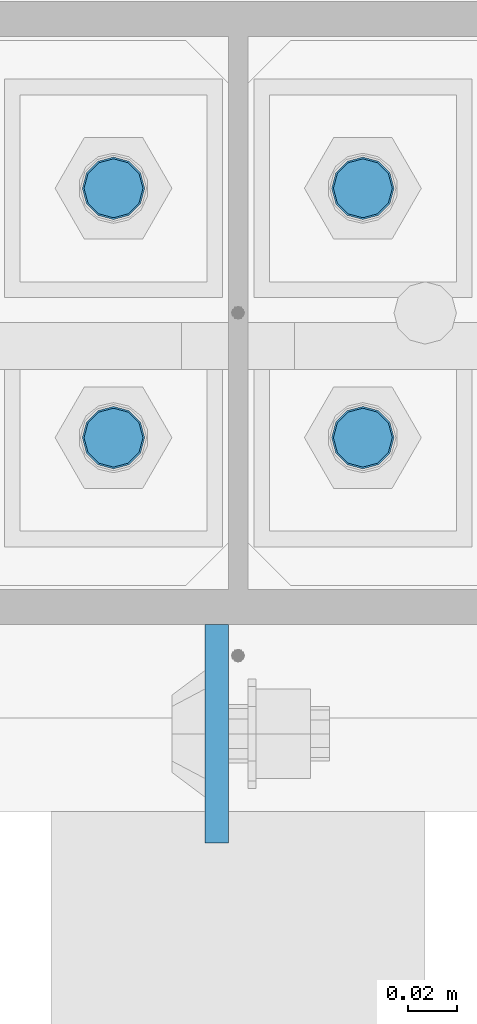
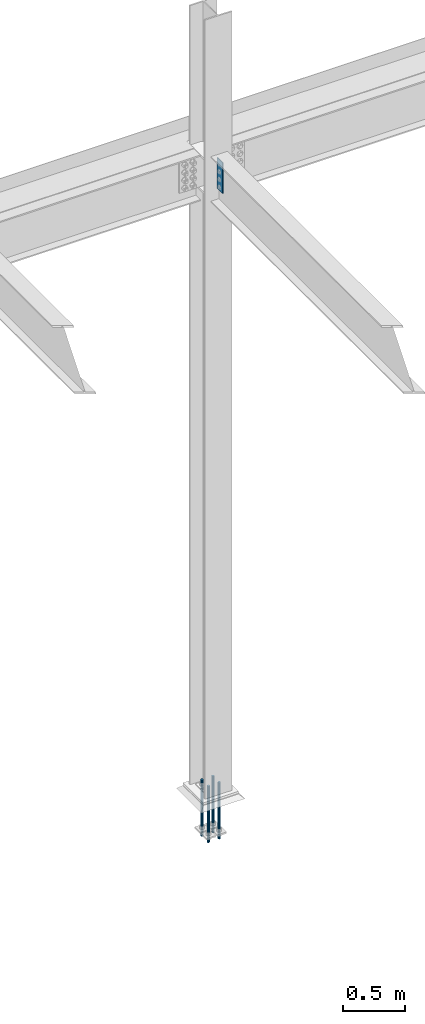
# One storey, part 1603 of 3843: 5 columns, 2 elements without a shape of their own.
"""IFC2X3 building model written with IfcOpenShell, lengths in millimetres."""

from ifc_helpers import new_model, si_unit, frame, origin_with_axes, place, context, subcontext, project, spatial, faceted_brep, material, type_object, element, aggregate, save


model = new_model("IFC2X3")

# Units and contexts
model_context = context("Model", 3, precision=1e-05, world=origin_with_axes())
body_context = subcontext(model_context, "Body", "Model", "MODEL_VIEW")
ifc_project = project(units=[si_unit("LENGTHUNIT", "METRE", prefix="MILLI"), si_unit("AREAUNIT", "SQUARE_METRE"), si_unit("VOLUMEUNIT", "CUBIC_METRE"), si_unit("MASSUNIT", "GRAM", prefix="KILO"), si_unit("TIMEUNIT", "SECOND"), si_unit("PLANEANGLEUNIT", "RADIAN"), si_unit("SOLIDANGLEUNIT", "STERADIAN"), si_unit("THERMODYNAMICTEMPERATUREUNIT", "DEGREE_CELSIUS"), si_unit("LUMINOUSINTENSITYUNIT", "LUMEN")], contexts=[model_context])

# Site, building, storey
site_placement = place(None, origin_with_axes())
site = spatial("IfcSite", under=ifc_project, at=site_placement, CompositionType="ELEMENT")
building_placement = place(site_placement, origin_with_axes())
building = spatial("IfcBuilding", under=site, at=building_placement, Name="Undefined", CompositionType="ELEMENT")
storey_placement = place(building_placement, origin_with_axes())
storey = spatial("IfcBuildingStorey", under=building, at=storey_placement, Name="Undefined", CompositionType="ELEMENT", Elevation=0.0)

# Assembly, columns
assembly_1_placement = place(storey_placement, origin_with_axes())
assembly_1 = element("IfcElementAssembly", 1, at=assembly_1_placement, inside=storey, Name="TEMPLATE", AssemblyPlace="NOTDEFINED", PredefinedType="RIGID_FRAME")
ifc_material_1 = material(Name="Undefined/F1554-GR.55")
column_type_1 = type_object("IfcColumnType", PredefinedType="NOTDEFINED")
column_1_placement = place(assembly_1_placement, frame((48945.8, 104508.3, 30022.8), z_axis=(0.0, -1.0, 0.0), x_axis=(0.0, 0.0, -1.0)))
column_1 = element("IfcColumn", 2, at=column_1_placement, type_object=column_type_1, material=ifc_material_1, Name="ANCHOR_ROD", context=body_context, shape_type="Brep", body=[
    faceted_brep([(-127.0, -10.3923048454162, 6.0), (-127.0, -6.0, 10.3923048454126), (-127.0, 0.0, 12.0), (-127.0, 6.0, 10.3923048454126), (-127.0, 10.3923048454162, 6.0), (-127.0, 12.0, 0.0), (-127.0, 10.3923048454162, -6.0), (-127.0, 6.0, -10.3923048454126), (-127.0, 0.0, -12.0), (-127.0, -6.0, -10.3923048454126), (-127.0, -10.3923048454162, -6.0), (-127.0, -12.0, 0.0), (0.0, 12.0, 0.0), (0.0, 10.3923048454162, -6.0), (0.0, 6.0, -10.3923048454126), (0.0, 0.0, -12.0), (0.0, -6.0, -10.3923048454126), (0.0, -10.3923048454162, -6.0), (0.0, -12.0, 0.0), (0.0, -10.3923048454162, 6.0), (0.0, -6.0, 10.3923048454126), (0.0, 0.0, 12.0), (0.0, 6.0, 10.3923048454126), (0.0, 10.3923048454162, 6.0), (0.0, -10.9985226280696, 6.34999999999854), (0.0, -6.35000000000582, 10.9985226280623), (0.0, 0.0, 12.6999999999971), (0.0, 6.35000000000582, 10.9985226280623), (0.0, 10.9985226280696, 6.34999999999854), (0.0, 12.6999999999971, 0.0), (0.0, 10.9985226280696, -6.34999999999854), (0.0, 6.35000000000582, -10.9985226280623), (0.0, 0.0, -12.6999999999971), (0.0, -6.35000000000582, -10.9985226280623), (0.0, -10.9985226280696, -6.34999999999854), (0.0, -12.6999999999971, 0.0), (304.799999999999, -12.6999999999971, 0.0), (304.799999999999, -10.9985226280623, 6.35000000000036), (304.799999999999, -6.34999999999854, 10.9985226280623), (304.799999999999, 0.0, 12.7000000000007), (304.799999999999, 6.34999999999854, 10.9985226280623), (304.799999999999, 10.9985226280623, 6.35000000000036), (304.799999999999, 12.6999999999971, 0.0), (304.799999999999, 10.9985226280623, -6.35000000000036), (304.799999999999, 6.34999999999854, -10.9985226280623), (304.799999999999, 0.0, -12.7000000000007), (304.799999999999, -6.34999999999854, -10.9985226280623), (304.799999999999, -10.9985226280623, -6.35000000000036), (304.799999999999, -6.0, 10.3923048454126), (304.799999999999, 0.0, 12.0), (304.799999999999, 6.0, 10.3923048454126), (304.799999999999, 10.3923048454162, 6.0), (304.799999999999, 12.0, 0.0), (304.799999999999, 10.3923048454162, -6.0), (304.799999999999, 6.0, -10.3923048454126), (304.799999999999, 0.0, -12.0), (304.799999999999, -6.0, -10.3923048454126), (304.799999999999, -10.3923048454162, -6.0), (304.799999999999, -12.0, 0.0), (304.799999999999, -10.3923048454162, 6.0), (431.799999999999, -6.0, -10.3923048454126), (431.799999999999, 0.0, -12.0), (431.799999999999, 6.0, -10.3923048454126), (431.799999999999, 10.3923048454162, -6.0), (431.799999999999, 12.0, 0.0), (431.799999999999, 10.3923048454162, 6.0), (431.799999999999, 6.0, 10.3923048454126), (431.799999999999, 0.0, 12.0), (431.799999999999, -6.0, 10.3923048454126), (431.799999999999, -10.3923048454162, 6.0), (431.799999999999, -12.0, 0.0), (431.799999999999, -10.3923048454162, -6.0)], [[[0, 1, 2, 3, 4, 5, 6, 7, 8, 9, 10, 11]], [[6, 5, 12, 13]], [[7, 6, 13, 14]], [[8, 7, 14, 15]], [[9, 8, 15, 16]], [[10, 9, 16, 17]], [[11, 10, 17, 18]], [[0, 11, 18, 19]], [[1, 0, 19, 20]], [[2, 1, 20, 21]], [[3, 2, 21, 22]], [[4, 3, 22, 23]], [[5, 4, 23, 12]], [[24, 25, 26, 27, 28, 29, 30, 31, 32, 33, 34, 35], [22, 21, 20, 19, 18, 17, 16, 15, 14, 13, 12, 23]], [[24, 35, 36, 37]], [[25, 24, 37, 38]], [[26, 25, 38, 39]], [[27, 26, 39, 40]], [[28, 27, 40, 41]], [[29, 28, 41, 42]], [[30, 29, 42, 43]], [[31, 30, 43, 44]], [[32, 31, 44, 45]], [[33, 32, 45, 46]], [[34, 33, 46, 47]], [[35, 34, 47, 36]], [[46, 45, 44, 43, 42, 41, 40, 39, 38, 37, 36, 47], [48, 49, 50, 51, 52, 53, 54, 55, 56, 57, 58, 59]], [[60, 61, 62, 63, 64, 65, 66, 67, 68, 69, 70, 71]], [[68, 67, 49, 48]], [[69, 68, 48, 59]], [[70, 69, 59, 58]], [[71, 70, 58, 57]], [[60, 71, 57, 56]], [[61, 60, 56, 55]], [[62, 61, 55, 54]], [[63, 62, 54, 53]], [[64, 63, 53, 52]], [[65, 64, 52, 51]], [[66, 65, 51, 50]], [[67, 66, 50, 49]]]),
])
column_2_placement = place(assembly_1_placement, frame((49047.4, 104508.3, 30022.8), z_axis=(0.0, 1.0, 0.0), x_axis=(0.0, 0.0, -1.0)))
column_2 = element("IfcColumn", 3, at=column_2_placement, type_object=column_type_1, material=ifc_material_1, Name="ANCHOR_ROD", context=body_context, shape_type="Brep", body=[
    faceted_brep([(-127.0, -10.3923048454162, 6.0), (-127.0, -6.0, 10.3923048454126), (-127.0, 0.0, 12.0), (-127.0, 6.0, 10.3923048454126), (-127.0, 10.3923048454162, 6.0), (-127.0, 12.0, 0.0), (-127.0, 10.3923048454162, -6.0), (-127.0, 6.0, -10.3923048454126), (-127.0, 0.0, -12.0), (-127.0, -6.0, -10.3923048454126), (-127.0, -10.3923048454162, -6.0), (-127.0, -12.0, 0.0), (0.0, 12.0, 0.0), (0.0, 10.3923048454162, -6.0), (0.0, 6.0, -10.3923048454126), (0.0, 0.0, -12.0), (0.0, -6.0, -10.3923048454126), (0.0, -10.3923048454162, -6.0), (0.0, -12.0, 0.0), (0.0, -10.3923048454162, 6.0), (0.0, -6.0, 10.3923048454126), (0.0, 0.0, 12.0), (0.0, 6.0, 10.3923048454126), (0.0, 10.3923048454162, 6.0), (0.0, -10.9985226280696, 6.34999999999854), (0.0, -6.35000000000582, 10.9985226280623), (0.0, 0.0, 12.6999999999971), (0.0, 6.35000000000582, 10.9985226280623), (0.0, 10.9985226280696, 6.34999999999854), (0.0, 12.6999999999971, 0.0), (0.0, 10.9985226280696, -6.34999999999854), (0.0, 6.35000000000582, -10.9985226280623), (0.0, 0.0, -12.6999999999971), (0.0, -6.35000000000582, -10.9985226280623), (0.0, -10.9985226280696, -6.34999999999854), (0.0, -12.6999999999971, 0.0), (304.799999999999, -12.6999999999971, 0.0), (304.799999999999, -10.9985226280623, 6.35000000000036), (304.799999999999, -6.34999999999854, 10.9985226280623), (304.799999999999, 0.0, 12.7000000000007), (304.799999999999, 6.34999999999854, 10.9985226280623), (304.799999999999, 10.9985226280623, 6.35000000000036), (304.799999999999, 12.6999999999971, 0.0), (304.799999999999, 10.9985226280623, -6.35000000000036), (304.799999999999, 6.34999999999854, -10.9985226280623), (304.799999999999, 0.0, -12.7000000000007), (304.799999999999, -6.34999999999854, -10.9985226280623), (304.799999999999, -10.9985226280623, -6.35000000000036), (304.799999999999, -6.0, 10.3923048454126), (304.799999999999, 0.0, 12.0), (304.799999999999, 6.0, 10.3923048454126), (304.799999999999, 10.3923048454162, 6.0), (304.799999999999, 12.0, 0.0), (304.799999999999, 10.3923048454162, -6.0), (304.799999999999, 6.0, -10.3923048454126), (304.799999999999, 0.0, -12.0), (304.799999999999, -6.0, -10.3923048454126), (304.799999999999, -10.3923048454162, -6.0), (304.799999999999, -12.0, 0.0), (304.799999999999, -10.3923048454162, 6.0), (431.799999999999, -6.0, -10.3923048454126), (431.799999999999, 0.0, -12.0), (431.799999999999, 6.0, -10.3923048454126), (431.799999999999, 10.3923048454162, -6.0), (431.799999999999, 12.0, 0.0), (431.799999999999, 10.3923048454162, 6.0), (431.799999999999, 6.0, 10.3923048454126), (431.799999999999, 0.0, 12.0), (431.799999999999, -6.0, 10.3923048454126), (431.799999999999, -10.3923048454162, 6.0), (431.799999999999, -12.0, 0.0), (431.799999999999, -10.3923048454162, -6.0)], [[[0, 1, 2, 3, 4, 5, 6, 7, 8, 9, 10, 11]], [[6, 5, 12, 13]], [[7, 6, 13, 14]], [[8, 7, 14, 15]], [[9, 8, 15, 16]], [[10, 9, 16, 17]], [[11, 10, 17, 18]], [[0, 11, 18, 19]], [[1, 0, 19, 20]], [[2, 1, 20, 21]], [[3, 2, 21, 22]], [[4, 3, 22, 23]], [[5, 4, 23, 12]], [[24, 25, 26, 27, 28, 29, 30, 31, 32, 33, 34, 35], [22, 21, 20, 19, 18, 17, 16, 15, 14, 13, 12, 23]], [[24, 35, 36, 37]], [[25, 24, 37, 38]], [[26, 25, 38, 39]], [[27, 26, 39, 40]], [[28, 27, 40, 41]], [[29, 28, 41, 42]], [[30, 29, 42, 43]], [[31, 30, 43, 44]], [[32, 31, 44, 45]], [[33, 32, 45, 46]], [[34, 33, 46, 47]], [[35, 34, 47, 36]], [[46, 45, 44, 43, 42, 41, 40, 39, 38, 37, 36, 47], [48, 49, 50, 51, 52, 53, 54, 55, 56, 57, 58, 59]], [[60, 61, 62, 63, 64, 65, 66, 67, 68, 69, 70, 71]], [[68, 67, 49, 48]], [[69, 68, 48, 59]], [[70, 69, 59, 58]], [[71, 70, 58, 57]], [[60, 71, 57, 56]], [[61, 60, 56, 55]], [[62, 61, 55, 54]], [[63, 62, 54, 53]], [[64, 63, 53, 52]], [[65, 64, 52, 51]], [[66, 65, 51, 50]], [[67, 66, 50, 49]]]),
])
column_3_placement = place(assembly_1_placement, frame((48945.8, 104609.9, 30022.8), z_axis=(0.0, -1.0, 0.0), x_axis=(0.0, 0.0, -1.0)))
column_3 = element("IfcColumn", 4, at=column_3_placement, type_object=column_type_1, material=ifc_material_1, Name="ANCHOR_ROD", context=body_context, shape_type="Brep", body=[
    faceted_brep([(-127.0, -10.3923048454162, 6.0), (-127.0, -6.0, 10.3923048454126), (-127.0, 0.0, 12.0), (-127.0, 6.0, 10.3923048454126), (-127.0, 10.3923048454162, 6.0), (-127.0, 12.0, 0.0), (-127.0, 10.3923048454162, -6.0), (-127.0, 6.0, -10.3923048454126), (-127.0, 0.0, -12.0), (-127.0, -6.0, -10.3923048454126), (-127.0, -10.3923048454162, -6.0), (-127.0, -12.0, 0.0), (0.0, 12.0, 0.0), (0.0, 10.3923048454162, -6.0), (0.0, 6.0, -10.3923048454126), (0.0, 0.0, -12.0), (0.0, -6.0, -10.3923048454126), (0.0, -10.3923048454162, -6.0), (0.0, -12.0, 0.0), (0.0, -10.3923048454162, 6.0), (0.0, -6.0, 10.3923048454126), (0.0, 0.0, 12.0), (0.0, 6.0, 10.3923048454126), (0.0, 10.3923048454162, 6.0), (0.0, -10.9985226280696, 6.34999999999854), (0.0, -6.35000000000582, 10.9985226280623), (0.0, 0.0, 12.6999999999971), (0.0, 6.35000000000582, 10.9985226280623), (0.0, 10.9985226280696, 6.34999999999854), (0.0, 12.6999999999971, 0.0), (0.0, 10.9985226280696, -6.34999999999854), (0.0, 6.35000000000582, -10.9985226280623), (0.0, 0.0, -12.6999999999971), (0.0, -6.35000000000582, -10.9985226280623), (0.0, -10.9985226280696, -6.34999999999854), (0.0, -12.6999999999971, 0.0), (304.799999999999, -12.6999999999971, 0.0), (304.799999999999, -10.9985226280623, 6.35000000000036), (304.799999999999, -6.34999999999854, 10.9985226280623), (304.799999999999, 0.0, 12.7000000000007), (304.799999999999, 6.34999999999854, 10.9985226280623), (304.799999999999, 10.9985226280623, 6.35000000000036), (304.799999999999, 12.6999999999971, 0.0), (304.799999999999, 10.9985226280623, -6.35000000000036), (304.799999999999, 6.34999999999854, -10.9985226280623), (304.799999999999, 0.0, -12.7000000000007), (304.799999999999, -6.34999999999854, -10.9985226280623), (304.799999999999, -10.9985226280623, -6.35000000000036), (304.799999999999, -6.0, 10.3923048454126), (304.799999999999, 0.0, 12.0), (304.799999999999, 6.0, 10.3923048454126), (304.799999999999, 10.3923048454162, 6.0), (304.799999999999, 12.0, 0.0), (304.799999999999, 10.3923048454162, -6.0), (304.799999999999, 6.0, -10.3923048454126), (304.799999999999, 0.0, -12.0), (304.799999999999, -6.0, -10.3923048454126), (304.799999999999, -10.3923048454162, -6.0), (304.799999999999, -12.0, 0.0), (304.799999999999, -10.3923048454162, 6.0), (431.799999999999, -6.0, -10.3923048454126), (431.799999999999, 0.0, -12.0), (431.799999999999, 6.0, -10.3923048454126), (431.799999999999, 10.3923048454162, -6.0), (431.799999999999, 12.0, 0.0), (431.799999999999, 10.3923048454162, 6.0), (431.799999999999, 6.0, 10.3923048454126), (431.799999999999, 0.0, 12.0), (431.799999999999, -6.0, 10.3923048454126), (431.799999999999, -10.3923048454162, 6.0), (431.799999999999, -12.0, 0.0), (431.799999999999, -10.3923048454162, -6.0)], [[[0, 1, 2, 3, 4, 5, 6, 7, 8, 9, 10, 11]], [[6, 5, 12, 13]], [[7, 6, 13, 14]], [[8, 7, 14, 15]], [[9, 8, 15, 16]], [[10, 9, 16, 17]], [[11, 10, 17, 18]], [[0, 11, 18, 19]], [[1, 0, 19, 20]], [[2, 1, 20, 21]], [[3, 2, 21, 22]], [[4, 3, 22, 23]], [[5, 4, 23, 12]], [[24, 25, 26, 27, 28, 29, 30, 31, 32, 33, 34, 35], [22, 21, 20, 19, 18, 17, 16, 15, 14, 13, 12, 23]], [[24, 35, 36, 37]], [[25, 24, 37, 38]], [[26, 25, 38, 39]], [[27, 26, 39, 40]], [[28, 27, 40, 41]], [[29, 28, 41, 42]], [[30, 29, 42, 43]], [[31, 30, 43, 44]], [[32, 31, 44, 45]], [[33, 32, 45, 46]], [[34, 33, 46, 47]], [[35, 34, 47, 36]], [[46, 45, 44, 43, 42, 41, 40, 39, 38, 37, 36, 47], [48, 49, 50, 51, 52, 53, 54, 55, 56, 57, 58, 59]], [[60, 61, 62, 63, 64, 65, 66, 67, 68, 69, 70, 71]], [[68, 67, 49, 48]], [[69, 68, 48, 59]], [[70, 69, 59, 58]], [[71, 70, 58, 57]], [[60, 71, 57, 56]], [[61, 60, 56, 55]], [[62, 61, 55, 54]], [[63, 62, 54, 53]], [[64, 63, 53, 52]], [[65, 64, 52, 51]], [[66, 65, 51, 50]], [[67, 66, 50, 49]]]),
])
column_4_placement = place(assembly_1_placement, frame((49047.4, 104609.9, 30022.8), z_axis=(0.0, 1.0, 0.0), x_axis=(0.0, 0.0, -1.0)))
column_4 = element("IfcColumn", 5, at=column_4_placement, type_object=column_type_1, material=ifc_material_1, Name="ANCHOR_ROD", context=body_context, shape_type="Brep", body=[
    faceted_brep([(-127.0, -10.3923048454162, 6.0), (-127.0, -6.0, 10.3923048454126), (-127.0, 0.0, 12.0), (-127.0, 6.0, 10.3923048454126), (-127.0, 10.3923048454162, 6.0), (-127.0, 12.0, 0.0), (-127.0, 10.3923048454162, -6.0), (-127.0, 6.0, -10.3923048454126), (-127.0, 0.0, -12.0), (-127.0, -6.0, -10.3923048454126), (-127.0, -10.3923048454162, -6.0), (-127.0, -12.0, 0.0), (0.0, 12.0, 0.0), (0.0, 10.3923048454162, -6.0), (0.0, 6.0, -10.3923048454126), (0.0, 0.0, -12.0), (0.0, -6.0, -10.3923048454126), (0.0, -10.3923048454162, -6.0), (0.0, -12.0, 0.0), (0.0, -10.3923048454162, 6.0), (0.0, -6.0, 10.3923048454126), (0.0, 0.0, 12.0), (0.0, 6.0, 10.3923048454126), (0.0, 10.3923048454162, 6.0), (0.0, -10.9985226280696, 6.34999999999854), (0.0, -6.35000000000582, 10.9985226280623), (0.0, 0.0, 12.6999999999971), (0.0, 6.35000000000582, 10.9985226280623), (0.0, 10.9985226280696, 6.34999999999854), (0.0, 12.6999999999971, 0.0), (0.0, 10.9985226280696, -6.34999999999854), (0.0, 6.35000000000582, -10.9985226280623), (0.0, 0.0, -12.6999999999971), (0.0, -6.35000000000582, -10.9985226280623), (0.0, -10.9985226280696, -6.34999999999854), (0.0, -12.6999999999971, 0.0), (304.799999999999, -12.6999999999971, 0.0), (304.799999999999, -10.9985226280623, 6.35000000000036), (304.799999999999, -6.34999999999854, 10.9985226280623), (304.799999999999, 0.0, 12.7000000000007), (304.799999999999, 6.34999999999854, 10.9985226280623), (304.799999999999, 10.9985226280623, 6.35000000000036), (304.799999999999, 12.6999999999971, 0.0), (304.799999999999, 10.9985226280623, -6.35000000000036), (304.799999999999, 6.34999999999854, -10.9985226280623), (304.799999999999, 0.0, -12.7000000000007), (304.799999999999, -6.34999999999854, -10.9985226280623), (304.799999999999, -10.9985226280623, -6.35000000000036), (304.799999999999, -6.0, 10.3923048454126), (304.799999999999, 0.0, 12.0), (304.799999999999, 6.0, 10.3923048454126), (304.799999999999, 10.3923048454162, 6.0), (304.799999999999, 12.0, 0.0), (304.799999999999, 10.3923048454162, -6.0), (304.799999999999, 6.0, -10.3923048454126), (304.799999999999, 0.0, -12.0), (304.799999999999, -6.0, -10.3923048454126), (304.799999999999, -10.3923048454162, -6.0), (304.799999999999, -12.0, 0.0), (304.799999999999, -10.3923048454162, 6.0), (431.799999999999, -6.0, -10.3923048454126), (431.799999999999, 0.0, -12.0), (431.799999999999, 6.0, -10.3923048454126), (431.799999999999, 10.3923048454162, -6.0), (431.799999999999, 12.0, 0.0), (431.799999999999, 10.3923048454162, 6.0), (431.799999999999, 6.0, 10.3923048454126), (431.799999999999, 0.0, 12.0), (431.799999999999, -6.0, 10.3923048454126), (431.799999999999, -10.3923048454162, 6.0), (431.799999999999, -12.0, 0.0), (431.799999999999, -10.3923048454162, -6.0)], [[[0, 1, 2, 3, 4, 5, 6, 7, 8, 9, 10, 11]], [[6, 5, 12, 13]], [[7, 6, 13, 14]], [[8, 7, 14, 15]], [[9, 8, 15, 16]], [[10, 9, 16, 17]], [[11, 10, 17, 18]], [[0, 11, 18, 19]], [[1, 0, 19, 20]], [[2, 1, 20, 21]], [[3, 2, 21, 22]], [[4, 3, 22, 23]], [[5, 4, 23, 12]], [[24, 25, 26, 27, 28, 29, 30, 31, 32, 33, 34, 35], [22, 21, 20, 19, 18, 17, 16, 15, 14, 13, 12, 23]], [[24, 35, 36, 37]], [[25, 24, 37, 38]], [[26, 25, 38, 39]], [[27, 26, 39, 40]], [[28, 27, 40, 41]], [[29, 28, 41, 42]], [[30, 29, 42, 43]], [[31, 30, 43, 44]], [[32, 31, 44, 45]], [[33, 32, 45, 46]], [[34, 33, 46, 47]], [[35, 34, 47, 36]], [[46, 45, 44, 43, 42, 41, 40, 39, 38, 37, 36, 47], [48, 49, 50, 51, 52, 53, 54, 55, 56, 57, 58, 59]], [[60, 61, 62, 63, 64, 65, 66, 67, 68, 69, 70, 71]], [[68, 67, 49, 48]], [[69, 68, 48, 59]], [[70, 69, 59, 58]], [[71, 70, 58, 57]], [[60, 71, 57, 56]], [[61, 60, 56, 55]], [[62, 61, 55, 54]], [[63, 62, 54, 53]], [[64, 63, 53, 52]], [[65, 64, 52, 51]], [[66, 65, 51, 50]], [[67, 66, 50, 49]]]),
])
aggregate(assembly_1, [column_1, column_2, column_3, column_4])

# Assembly, column
assembly_2_placement = place(storey_placement, origin_with_axes())
assembly_2 = element("IfcElementAssembly", 6, at=assembly_2_placement, inside=storey, Name="COLUMN", AssemblyPlace="NOTDEFINED", PredefinedType="RIGID_FRAME")
ifc_material_2 = material(Name="STEEL/A572-50")
column_type_2 = type_object("IfcColumnType", PredefinedType="NOTDEFINED")
column_5_placement = place(assembly_2_placement, frame((48987.8695000649, 104387.65, 36093.4), z_axis=(0.0, 1.0, 0.0), x_axis=(0.0, 0.0, 1.0)))
column_5 = element("IfcColumn", 7, at=column_5_placement, type_object=column_type_2, material=ifc_material_2, Name="PLATE", context=body_context, shape_type="Brep", body=[
    faceted_brep([(0.0, 4.76249999999709, -44.4500000000007), (0.0, 4.76249999999709, 44.4500000000007), (304.799999999996, 4.76249999999709, 44.4500000000007), (304.799999999996, 4.76249999999709, -44.4500000000007), (0.0, -4.76249999999709, 44.4500000000007), (304.799999999996, -4.76249999999709, 44.4500000000007), (0.0, -4.76249999999709, -44.4500000000007), (304.799999999996, -4.76249999999709, -44.4500000000007)], [[[0, 1, 2, 3]], [[1, 4, 5, 2]], [[4, 6, 7, 5]], [[6, 0, 3, 7]], [[5, 7, 3, 2]], [[6, 4, 1, 0]]]),
])
aggregate(assembly_2, [column_5])

save(model, "model.ifc")
